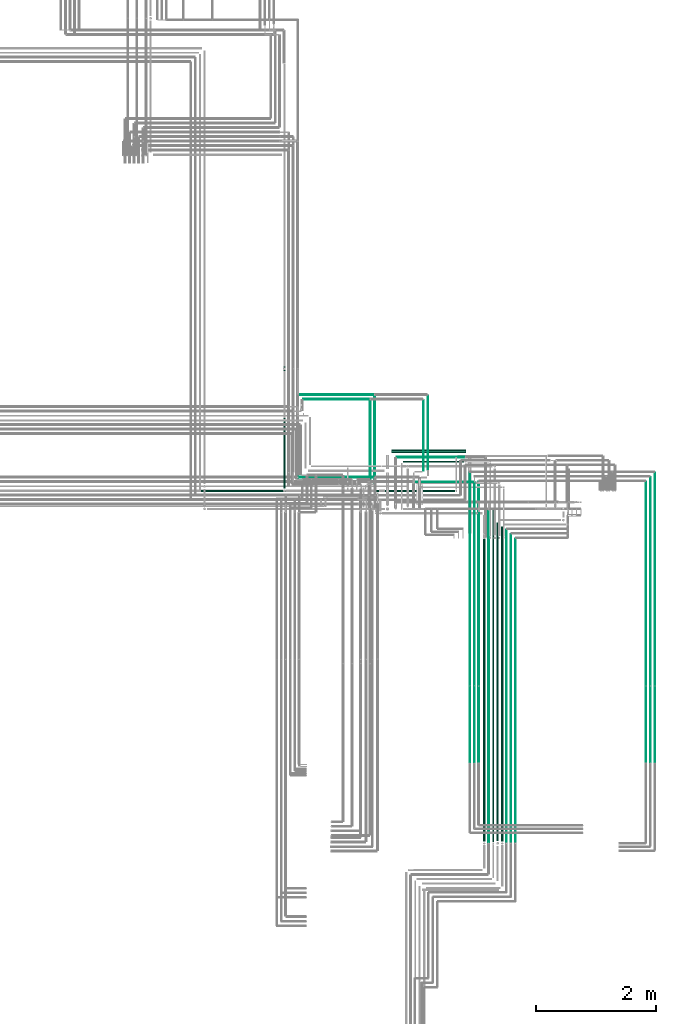
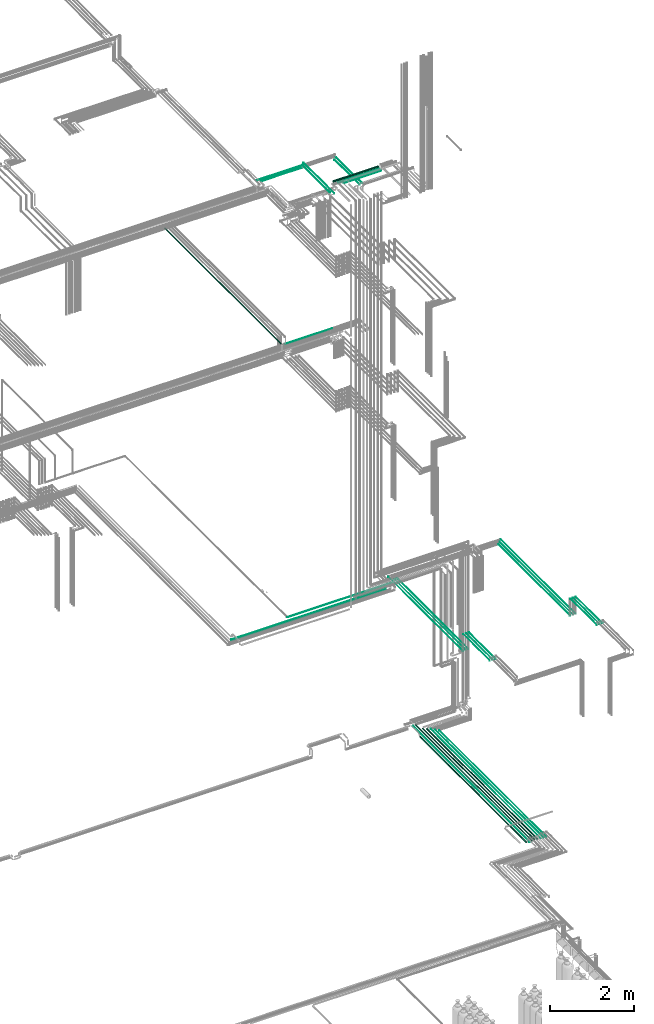
# One storey, part 85 of 331: 33 flow segments.
"""IFC2X3 building model written with IfcOpenShell, lengths in millimetres."""

from ifc_helpers import new_model, entity, si_unit, converted_unit, derived_unit, direction, frame, frame_2d, origin, origin_2d_with_axis, place, context, subcontext, project, spatial, circle, extrude, type_object, element, save


model = new_model("IFC2X3")

# Units and contexts
model_context = context("Model", 3, precision=0.01, world=origin(), true_north=direction((6.12303176911189e-17, 1.0)))
body_context = subcontext(model_context, "Body", "Model", "MODEL_VIEW")
ifc_project = project(units=[si_unit("LENGTHUNIT", "METRE", prefix="MILLI"), si_unit("AREAUNIT", "SQUARE_METRE"), si_unit("VOLUMEUNIT", "CUBIC_METRE"), converted_unit("PLANEANGLEUNIT", "DEGREE", entity("IfcRatioMeasure", 0.0174532925199433), si_unit("PLANEANGLEUNIT", "RADIAN"), dimensions=[0, 0, 0, 0, 0, 0, 0]), si_unit("MASSUNIT", "GRAM", prefix="KILO"), derived_unit("MASSDENSITYUNIT", [(si_unit("MASSUNIT", "GRAM", prefix="KILO"), 1), (si_unit("LENGTHUNIT", "METRE"), -3)]), derived_unit("MOMENTOFINERTIAUNIT", [(si_unit("LENGTHUNIT", "METRE"), 4)]), si_unit("TIMEUNIT", "SECOND"), si_unit("FREQUENCYUNIT", "HERTZ"), si_unit("THERMODYNAMICTEMPERATUREUNIT", "DEGREE_CELSIUS"), derived_unit("THERMALTRANSMITTANCEUNIT", [(si_unit("MASSUNIT", "GRAM", prefix="KILO"), 1), (si_unit("THERMODYNAMICTEMPERATUREUNIT", "KELVIN"), -1), (si_unit("TIMEUNIT", "SECOND"), -3)]), derived_unit("VOLUMETRICFLOWRATEUNIT", [(si_unit("LENGTHUNIT", "METRE"), 3), (si_unit("TIMEUNIT", "SECOND"), -1)]), derived_unit("MASSFLOWRATEUNIT", [(si_unit("MASSUNIT", "GRAM", prefix="KILO"), 1), (si_unit("TIMEUNIT", "SECOND"), -1)]), derived_unit("ROTATIONALFREQUENCYUNIT", [(si_unit("TIMEUNIT", "SECOND"), -1)]), si_unit("ELECTRICCURRENTUNIT", "AMPERE"), si_unit("ELECTRICVOLTAGEUNIT", "VOLT"), si_unit("POWERUNIT", "WATT"), si_unit("FORCEUNIT", "NEWTON", prefix="KILO"), si_unit("ILLUMINANCEUNIT", "LUX"), si_unit("LUMINOUSFLUXUNIT", "LUMEN"), si_unit("LUMINOUSINTENSITYUNIT", "CANDELA"), derived_unit("USERDEFINED", [(si_unit("MASSUNIT", "GRAM", prefix="KILO"), -1), (si_unit("LENGTHUNIT", "METRE"), -2), (si_unit("TIMEUNIT", "SECOND"), 3), (si_unit("LUMINOUSFLUXUNIT", "LUMEN"), 1)]), derived_unit("LINEARVELOCITYUNIT", [(si_unit("LENGTHUNIT", "METRE"), 1), (si_unit("TIMEUNIT", "SECOND"), -1)]), si_unit("PRESSUREUNIT", "PASCAL"), derived_unit("USERDEFINED", [(si_unit("LENGTHUNIT", "METRE"), -2), (si_unit("MASSUNIT", "GRAM", prefix="KILO"), 1), (si_unit("TIMEUNIT", "SECOND"), -2)]), derived_unit("LINEARFORCEUNIT", [(si_unit("MASSUNIT", "GRAM", prefix="KILO"), 1), (si_unit("LENGTHUNIT", "METRE"), 1), (si_unit("TIMEUNIT", "SECOND"), -2), (si_unit("LENGTHUNIT", "METRE"), -1)]), derived_unit("PLANARFORCEUNIT", [(si_unit("MASSUNIT", "GRAM", prefix="KILO"), 1), (si_unit("LENGTHUNIT", "METRE"), 1), (si_unit("TIMEUNIT", "SECOND"), -2), (si_unit("LENGTHUNIT", "METRE"), -2)])], contexts=[model_context])

# Site, building, storey
site_placement = place(None, frame((0.0, -0.00077364408347762, 0.0)))
site = spatial("IfcSite", under=ifc_project, at=site_placement, CompositionType="ELEMENT")
building_placement = place(site_placement, origin())
building = spatial("IfcBuilding", under=site, at=building_placement, CompositionType="ELEMENT")
storey_placement = place(building_placement, origin())
storey = spatial("IfcBuildingStorey", under=building, at=storey_placement, CompositionType="ELEMENT", Elevation=0.0)

# Flow segments
pipe_segment_type = type_object("IfcPipeSegmentType", PredefinedType="NOTDEFINED")
flow_segment_1_placement = place(building_placement, frame((65391.016630958, 2592.99994915063, 2690.90472776409)))
element("IfcFlowSegment", 1, at=flow_segment_1_placement, inside=storey, type_object=pipe_segment_type, context=body_context, shape_type="SweptSolid", body=[
    extrude(circle(Radius=7.5, at=origin_2d_with_axis()), frame((9.09527223592286, 0.0, 9.09527223591582), z_axis=(0.0, 1.0, 0.0), x_axis=(1.0, 0.0, 0.0)), (0.0, 0.0, 1.0), 5521.00069324442),
])
flow_segment_2_placement = place(building_placement, frame((65462.516630958, 2598.99994915063, 2687.40472776409)))
element("IfcFlowSegment", 2, at=flow_segment_2_placement, inside=storey, type_object=pipe_segment_type, context=body_context, shape_type="SweptSolid", body=[
    extrude(circle(Radius=11.0, at=frame_2d((0.0, -5.41433564649196e-13), x_axis=(1.0, 0.0))), frame((12.5952722359134, 0.0, 12.5952722359156), z_axis=(0.0, 1.0, 0.0), x_axis=(1.0, 0.0, 0.0)), (0.0, 0.0, 1.0), 5524.93031773049),
])
flow_segment_3_placement = place(building_placement, frame((65531.016630958, 2614.99994915063, 2680.90472776408)))
element("IfcFlowSegment", 3, at=flow_segment_3_placement, inside=storey, type_object=pipe_segment_type, context=body_context, shape_type="SweptSolid", body=[
    extrude(circle(Radius=17.5, at=origin_2d_with_axis()), frame((19.0952722359206, 0.0, 19.0952722359157), z_axis=(0.0, 1.0, 0.0), x_axis=(1.0, 0.0, 0.0)), (0.0, 0.0, 1.0), 5307.93031773052),
])
flow_segment_4_placement = place(building_placement, frame((65227.5100168243, 5214.0, 6742.40472776408)))
element("IfcFlowSegment", 4, at=flow_segment_4_placement, inside=storey, type_object=pipe_segment_type, context=body_context, shape_type="SweptSolid", body=[
    extrude(circle(Radius=6.0, at=frame_2d((0.0, -1.08286712929839e-12), x_axis=(1.0, 0.0))), frame((7.59527223591454, 0.0, 7.5952722359167), z_axis=(0.0, 1.0, 0.0), x_axis=(-1.0, 0.0, 0.0)), (0.0, 0.0, 1.0), 3387.00006564344),
])
flow_segment_5_placement = place(storey_placement, frame((61976.0132590569, 8490.62056382732, 14730.9047277641)))
element("IfcFlowSegment", 5, at=flow_segment_5_placement, inside=storey, type_object=pipe_segment_type, context=body_context, shape_type="SweptSolid", body=[
    extrude(circle(Radius=17.5, at=origin_2d_with_axis()), frame((19.0952722359119, 0.0, 19.0952722359163), z_axis=(0.0, 1.0, 0.0), x_axis=(1.0, 0.0, 0.0)), (0.0, 0.0, 1.0), 5519.37943617271),
])
flow_segment_6_placement = place(storey_placement, frame((68011.5232052592, 5214.0, 6742.40472776408)))
element("IfcFlowSegment", 6, at=flow_segment_6_placement, inside=storey, type_object=pipe_segment_type, context=body_context, shape_type="SweptSolid", body=[
    extrude(circle(Radius=6.0, at=frame_2d((0.0, -1.08286712929839e-12), x_axis=(1.0, 0.0))), frame((7.59527223591454, 0.0, 7.5952722359167), z_axis=(0.0, 1.0, 0.0), x_axis=(-1.0, 0.0, 0.0)), (0.0, 0.0, 1.0), 3387.00006564344),
])
flow_segment_7_placement = place(storey_placement, frame((68088.5232052591, 5210.0, 6744.40472776408)))
element("IfcFlowSegment", 7, at=flow_segment_7_placement, inside=storey, type_object=pipe_segment_type, context=body_context, shape_type="SweptSolid", body=[
    extrude(circle(Radius=4.0, at=frame_2d((-1.73258740687743e-11, 0.0), x_axis=(1.0, 0.0))), frame((5.59527223593232, 0.0, 5.59527223591607), z_axis=(0.0, 1.0, 0.0), x_axis=(-1.0, 0.0, 0.0)), (0.0, 0.0, 1.0), 3470.00006564345),
])
flow_segment_8_placement = place(storey_placement, frame((68163.5232052592, 5210.00064239504, 6744.40472776408)))
element("IfcFlowSegment", 8, at=flow_segment_8_placement, inside=storey, type_object=pipe_segment_type, context=body_context, shape_type="SweptSolid", body=[
    extrude(circle(Radius=4.0, at=origin_2d_with_axis()), frame((5.59527223591499, 0.0, 5.59527223591607), z_axis=(0.0, 1.0, 0.0), x_axis=(-1.0, 0.0, 0.0)), (0.0, 0.0, 1.0), 3544.9994232484),
])
flow_segment_9_placement = place(storey_placement, frame((63777.6118832776, 9081.55315095605, 18421.4047277641)))
element("IfcFlowSegment", 9, at=flow_segment_9_placement, inside=storey, type_object=pipe_segment_type, context=body_context, shape_type="SweptSolid", body=[
    extrude(circle(Radius=27.0, at=origin_2d_with_axis()), frame((0.0, 28.5952722359163, 28.5952722359163), z_axis=(1.0, 0.0, 0.0), x_axis=(0.0, -1.0, 0.0)), (0.0, 0.0, 1.0), 1242.50000000009),
])
flow_segment_10_placement = place(storey_placement, frame((63869.1118832776, 9000.71546224627, 18440.9047277641)))
element("IfcFlowSegment", 10, at=flow_segment_10_placement, inside=storey, type_object=pipe_segment_type, context=body_context, shape_type="SweptSolid", body=[
    extrude(circle(Radius=7.5, at=origin_2d_with_axis()), frame((0.0, 9.09527223591853, 9.09527223591636), z_axis=(1.0, 0.0, 0.0), x_axis=(0.0, -1.0, 0.0)), (0.0, 0.0, 1.0), 1124.00000000001),
])
flow_segment_11_placement = place(storey_placement, frame((63975.1118832776, 8922.21546224628, 18437.4047277641)))
element("IfcFlowSegment", 11, at=flow_segment_11_placement, inside=storey, type_object=pipe_segment_type, context=body_context, shape_type="SweptSolid", body=[
    extrude(circle(Radius=11.0, at=origin_2d_with_axis()), frame((0.0, 12.595272235921, 12.5952722359156), z_axis=(1.0, 0.0, 0.0), x_axis=(0.0, -1.0, 0.0)), (0.0, 0.0, 1.0), 1012.00000000001),
])
flow_segment_12_placement = place(storey_placement, frame((64379.0166110417, 8801.65411069325, 18365.9047277641)))
element("IfcFlowSegment", 12, at=flow_segment_12_placement, inside=storey, type_object=pipe_segment_type, context=body_context, shape_type="SweptSolid", body=[
    extrude(circle(Radius=7.5, at=frame_2d((0.0, -2.16573425859679e-12), x_axis=(1.0, 0.0))), frame((9.09527223591419, 0.0, 9.09527223591419), z_axis=(0.0, 1.0, 0.0), x_axis=(1.0, 0.0, 0.0)), (0.0, 0.0, 1.0), 1230.34588930667),
])
flow_segment_13_placement = place(storey_placement, frame((62239.1900385654, 10040.904727764, 18440.9047277641)))
element("IfcFlowSegment", 13, at=flow_segment_13_placement, inside=storey, type_object=pipe_segment_type, context=body_context, shape_type="SweptSolid", body=[
    extrude(circle(Radius=7.5, at=frame_2d((0.0, -2.16573425859679e-12), x_axis=(1.0, 0.0))), frame((0.0, 9.09527223591636, 9.09527223591853), z_axis=(1.0, 0.0, 0.0), x_axis=(0.0, 1.0, 0.0)), (0.0, 0.0, 1.0), 1253.92184471218),
])
flow_segment_14_placement = place(building_placement, frame((64304.0166110417, 8785.93026688114, 18365.9047277641)))
element("IfcFlowSegment", 14, at=flow_segment_14_placement, inside=storey, type_object=pipe_segment_type, context=body_context, shape_type="SweptSolid", body=[
    extrude(circle(Radius=7.5, at=origin_2d_with_axis()), frame((9.09527223591419, 0.0, 9.09527223591636), z_axis=(0.0, 1.0, 0.0), x_axis=(1.0, 0.0, 0.0)), (0.0, 0.0, 1.0), 1171.06973311877),
])
flow_segment_15_placement = place(storey_placement, frame((62227.1085312929, 8668.02529159145, 14542.4047277641)))
element("IfcFlowSegment", 15, at=flow_segment_15_placement, inside=storey, type_object=pipe_segment_type, context=body_context, shape_type="SweptSolid", body=[
    extrude(circle(Radius=6.0, at=frame_2d((1.08286712929839e-12, 0.0), x_axis=(1.0, 0.0))), frame((0.0, 7.5952722359167, 7.5952722359167), z_axis=(1.0, 0.0, 0.0), x_axis=(0.0, 1.0, 0.0)), (0.0, 0.0, 1.0), 1276.0033519848),
])
flow_segment_16_placement = place(building_placement, frame((65227.5100168243, 3926.49985270762, 7242.40472776409)))
element("IfcFlowSegment", 16, at=flow_segment_16_placement, inside=storey, type_object=pipe_segment_type, context=body_context, shape_type="SweptSolid", body=[
    extrude(circle(Radius=6.0, at=frame_2d((-8.66293703438714e-12, 0.0), x_axis=(1.0, 0.0))), frame((7.59527223591454, 0.0, 7.59527223591562), z_axis=(0.0, 1.0, 0.0), x_axis=(-1.0, 0.0, 0.0)), (0.0, 0.0, 1.0), 1259.50014729239),
])
flow_segment_17_placement = place(building_placement, frame((65154.5100168243, 3929.49985270762, 7244.40472776409)))
element("IfcFlowSegment", 17, at=flow_segment_17_placement, inside=storey, type_object=pipe_segment_type, context=body_context, shape_type="SweptSolid", body=[
    extrude(circle(Radius=4.0, at=frame_2d((-8.66293703438714e-12, 0.0), x_axis=(1.0, 0.0))), frame((5.59527223591499, 0.0, 5.59527223591607), z_axis=(0.0, 1.0, 0.0), x_axis=(-1.0, 0.0, 0.0)), (0.0, 0.0, 1.0), 1260.50014729239),
])
flow_segment_18_placement = place(building_placement, frame((65079.5100168243, 3929.49985270762, 7244.40472776409)))
element("IfcFlowSegment", 18, at=flow_segment_18_placement, inside=storey, type_object=pipe_segment_type, context=body_context, shape_type="SweptSolid", body=[
    extrude(circle(Radius=4.0, at=frame_2d((-8.66293703438714e-12, 0.0), x_axis=(1.0, 0.0))), frame((5.59527223591499, 0.0, 5.59527223591607), z_axis=(0.0, 1.0, 0.0), x_axis=(-1.0, 0.0, 0.0)), (0.0, 0.0, 1.0), 1260.50078968743),
])
flow_segment_19_placement = place(storey_placement, frame((68011.5232052591, 3935.49985270762, 7242.40472776409)))
element("IfcFlowSegment", 19, at=flow_segment_19_placement, inside=storey, type_object=pipe_segment_type, context=body_context, shape_type="SweptSolid", body=[
    extrude(circle(Radius=6.0, at=frame_2d((-8.66293703438714e-12, 0.0), x_axis=(1.0, 0.0))), frame((7.5952722359232, 0.0, 7.59527223591562), z_axis=(0.0, 1.0, 0.0), x_axis=(-1.0, 0.0, 0.0)), (0.0, 0.0, 1.0), 1250.5001472924),
])
flow_segment_20_placement = place(storey_placement, frame((68088.5232052591, 3929.49985270761, 7244.40472776409)))
element("IfcFlowSegment", 20, at=flow_segment_20_placement, inside=storey, type_object=pipe_segment_type, context=body_context, shape_type="SweptSolid", body=[
    extrude(circle(Radius=4.0, at=frame_2d((-8.66293703438714e-12, 0.0), x_axis=(1.0, 0.0))), frame((5.59527223591499, 0.0, 5.59527223591607), z_axis=(0.0, 1.0, 0.0), x_axis=(-1.0, 0.0, 0.0)), (0.0, 0.0, 1.0), 1260.5001472924),
])
flow_segment_21_placement = place(storey_placement, frame((68163.5232052591, 3929.49985270761, 7244.40472776409)))
element("IfcFlowSegment", 21, at=flow_segment_21_placement, inside=storey, type_object=pipe_segment_type, context=body_context, shape_type="SweptSolid", body=[
    extrude(circle(Radius=4.0, at=frame_2d((-8.66293703438714e-12, 0.0), x_axis=(1.0, 0.0))), frame((5.59527223591499, 0.0, 5.59527223591607), z_axis=(0.0, 1.0, 0.0), x_axis=(-1.0, 0.0, 0.0)), (0.0, 0.0, 1.0), 1260.50078968744),
])
flow_segment_22_placement = place(storey_placement, frame((65079.5100168242, 5210.00064239503, 6744.40472776408)))
element("IfcFlowSegment", 22, at=flow_segment_22_placement, inside=storey, type_object=pipe_segment_type, context=body_context, shape_type="SweptSolid", body=[
    extrude(circle(Radius=4.0, at=frame_2d((0.0, -1.08286712929839e-12), x_axis=(1.0, 0.0))), frame((5.59527223591499, 0.0, 5.59527223591716), z_axis=(0.0, 1.0, 0.0), x_axis=(-1.0, 0.0, 0.0)), (0.0, 0.0, 1.0), 3544.9994232484),
])
flow_segment_23_placement = place(storey_placement, frame((60613.9967651366, 8435.39243233186, 6662.40472776408)))
element("IfcFlowSegment", 23, at=flow_segment_23_placement, inside=storey, type_object=pipe_segment_type, context=body_context, shape_type="SweptSolid", body=[
    extrude(circle(Radius=11.0, at=frame_2d((2.70716782324598e-11, 0.0), x_axis=(1.0, 0.0))), frame((0.0, 12.5952722359416, 12.5952722359156), z_axis=(1.0, 0.0, 0.0), x_axis=(0.0, 1.0, 0.0)), (0.0, 0.0, 1.0), 4222.10852392355),
])
flow_segment_24_placement = place(storey_placement, frame((62234.9975830078, 8592.39243233186, 6669.40472776406)))
element("IfcFlowSegment", 24, at=flow_segment_24_placement, inside=storey, type_object=pipe_segment_type, context=body_context, shape_type="SweptSolid", body=[
    extrude(circle(Radius=4.0, at=frame_2d((2.81545453617582e-11, 1.08286712929839e-12), x_axis=(1.0, 0.0))), frame((0.0, 5.59527223594314, 5.59527223591499), z_axis=(1.0, 0.0, 0.0), x_axis=(0.0, 1.0, 0.0)), (0.0, 0.0, 1.0), 2915.1077060524),
])
flow_segment_25_placement = place(storey_placement, frame((62314.1900385657, 9965.904727764, 18440.9047277641)))
element("IfcFlowSegment", 25, at=flow_segment_25_placement, inside=storey, type_object=pipe_segment_type, context=body_context, shape_type="SweptSolid", body=[
    extrude(circle(Radius=7.5, at=frame_2d((-2.16573425859679e-12, 0.0), x_axis=(1.0, 0.0))), frame((0.0, 9.09527223591853, 9.09527223591636), z_axis=(1.0, 0.0, 0.0), x_axis=(0.0, 1.0, 0.0)), (0.0, 0.0, 1.0), 1103.92184471191),
])
flow_segment_26_placement = place(building_placement, frame((63493.5166110417, 8573.81073448244, 18517.4047277641)))
element("IfcFlowSegment", 26, at=flow_segment_26_placement, inside=storey, type_object=pipe_segment_type, context=body_context, shape_type="SweptSolid", body=[
    extrude(circle(Radius=6.0, at=frame_2d((8.66293703438714e-12, 0.0), x_axis=(1.0, 0.0))), frame((7.5952722359232, 0.0, 7.5952722359167), z_axis=(0.0, 1.0, 0.0), x_axis=(-1.0, 0.0, 0.0)), (0.0, 0.0, 1.0), 1462.18926551748),
])
flow_segment_27_placement = place(storey_placement, frame((63417.0166110417, 8652.81073448245, 18515.9047277641)))
element("IfcFlowSegment", 27, at=flow_segment_27_placement, inside=storey, type_object=pipe_segment_type, context=body_context, shape_type="SweptSolid", body=[
    extrude(circle(Radius=7.5, at=frame_2d((8.66293703438714e-12, 0.0), x_axis=(1.0, 0.0))), frame((9.09527223592286, 0.0, 9.09527223591636), z_axis=(0.0, 1.0, 0.0), x_axis=(-1.0, 0.0, 0.0)), (0.0, 0.0, 1.0), 1304.18926551747),
])
flow_segment_28_placement = place(building_placement, frame((65309.5166309581, 2608.99994915063, 2684.40472776406)))
element("IfcFlowSegment", 28, at=flow_segment_28_placement, inside=storey, type_object=pipe_segment_type, context=body_context, shape_type="SweptSolid", body=[
    extrude(circle(Radius=14.0, at=frame_2d((8.66293703438714e-12, 0.0), x_axis=(1.0, 0.0))), frame((15.5952722359127, 0.0, 15.595272235916), z_axis=(0.0, 1.0, 0.0), x_axis=(-1.0, 0.0, 0.0)), (0.0, 0.0, 1.0), 5035.00005084935),
])
flow_segment_29_placement = place(building_placement, frame((65609.516630958, 2608.99994915063, 2684.40472776408)))
element("IfcFlowSegment", 29, at=flow_segment_29_placement, inside=storey, type_object=pipe_segment_type, context=body_context, shape_type="SweptSolid", body=[
    extrude(circle(Radius=14.0, at=frame_2d((8.66293703438714e-12, 0.0), x_axis=(1.0, 0.0))), frame((15.59527223593, 0.0, 15.595272235916), z_axis=(0.0, 1.0, 0.0), x_axis=(-1.0, 0.0, 0.0)), (0.0, 0.0, 1.0), 5244.93031773051),
])
flow_segment_30_placement = place(building_placement, frame((65694.516630958, 2583.99994915063, 2694.40472776407)))
element("IfcFlowSegment", 30, at=flow_segment_30_placement, inside=storey, type_object=pipe_segment_type, context=body_context, shape_type="SweptSolid", body=[
    extrude(circle(Radius=4.0, at=origin_2d_with_axis()), frame((5.59527223591499, 0.0, 5.59527223591607), z_axis=(0.0, 1.0, 0.0), x_axis=(-1.0, 0.0, 0.0)), (0.0, 0.0, 1.0), 5219.93031773051),
])
flow_segment_31_placement = place(building_placement, frame((65769.516630958, 2583.99994915063, 2694.40472776407)))
element("IfcFlowSegment", 31, at=flow_segment_31_placement, inside=storey, type_object=pipe_segment_type, context=body_context, shape_type="SweptSolid", body=[
    extrude(circle(Radius=4.0, at=frame_2d((1.73258740687743e-11, 0.0), x_axis=(1.0, 0.0))), frame((5.59527223593232, 0.0, 5.59527223591607), z_axis=(0.0, 1.0, 0.0), x_axis=(-1.0, 0.0, 0.0)), (0.0, 0.0, 1.0), 5144.93031773051),
])
flow_segment_32_placement = place(building_placement, frame((65844.516630958, 2583.99994915063, 2694.40472776408)))
element("IfcFlowSegment", 32, at=flow_segment_32_placement, inside=storey, type_object=pipe_segment_type, context=body_context, shape_type="SweptSolid", body=[
    extrude(circle(Radius=4.0, at=origin_2d_with_axis()), frame((5.59527223591499, 0.0, 5.59527223591607), z_axis=(0.0, 1.0, 0.0), x_axis=(-1.0, 0.0, 0.0)), (0.0, 0.0, 1.0), 5069.93031773051),
])
flow_segment_33_placement = place(storey_placement, frame((65154.5100168243, 5209.9891765507, 6744.65416270985)))
element("IfcFlowSegment", 33, at=flow_segment_33_placement, inside=storey, type_object=pipe_segment_type, context=body_context, shape_type="SweptSolid", body=[
    extrude(circle(Radius=4.0, at=frame_2d((0.0, 1.08286268054669e-12), x_axis=(1.0, 0.0))), frame((5.59527223591499, 0.011465844330661, 15.2924964576824), z_axis=(0.0, 0.999995891691992, -0.00286646108266176), x_axis=(-1.0, 0.0, 0.0)), (0.0, 0.0, 1.0), 3383.00098112432),
])

save(model, "model.ifc")
